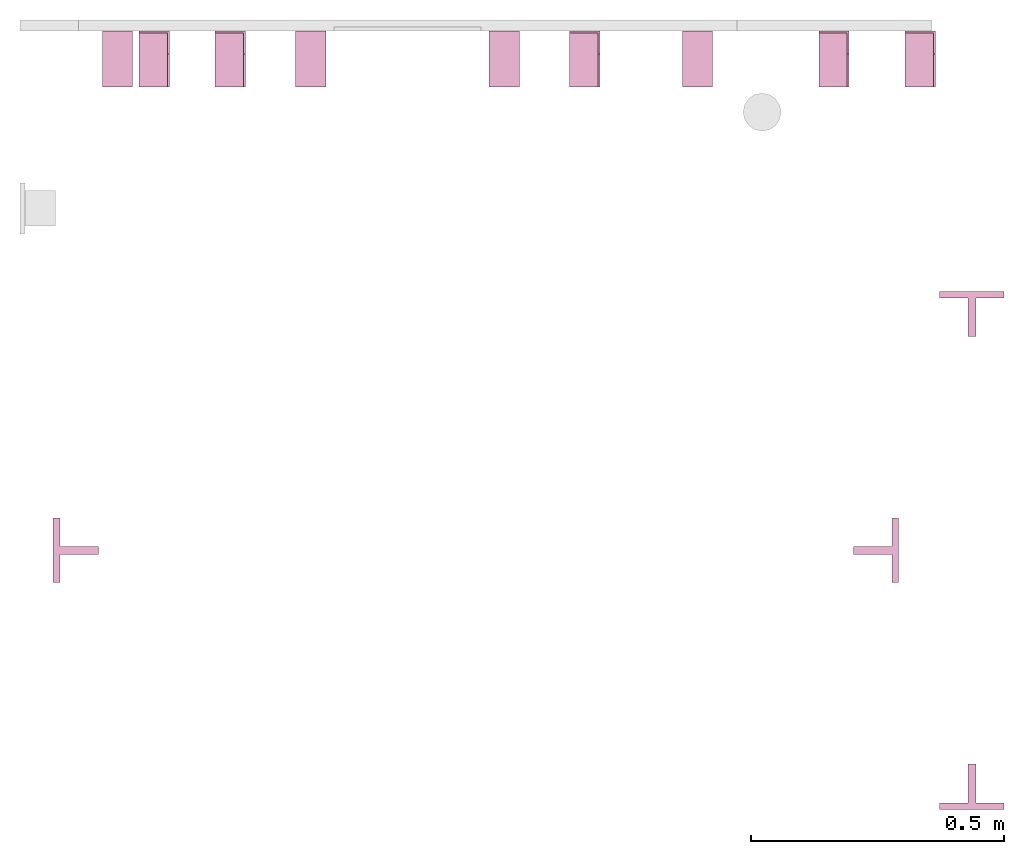
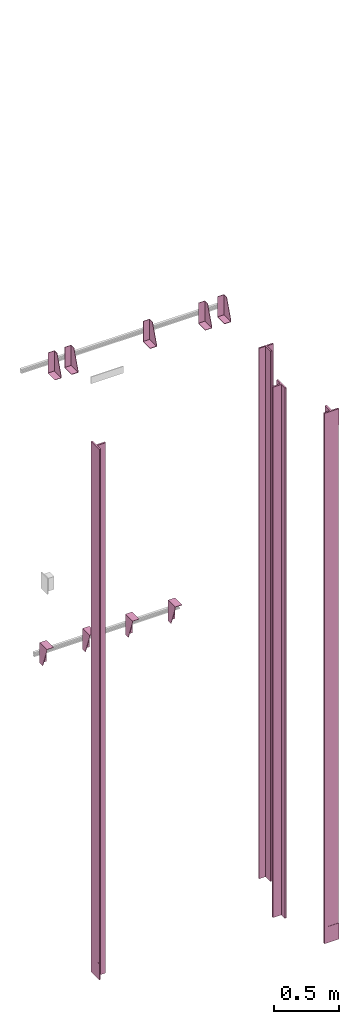
# One storey, part 3 of 3: 13 transport elements.
"""IFC4 building model written with IfcOpenShell, lengths in millimetres."""

from ifc_helpers import new_model, entity, si_unit, converted_unit, frame, origin_with_axes, place, context, subcontext, project, spatial, faceted_brep, element, save


model = new_model("IFC4")

# Units and contexts
context_of_model = context(None, 3, precision=0.01, world=origin_with_axes())
sub_context_1 = subcontext(context_of_model, None, None, "MODEL_VIEW")
sub_context_2 = subcontext(context_of_model, None, None, "MODEL_VIEW")
sub_context_3 = subcontext(context_of_model, None, None, "MODEL_VIEW")
sub_context_4 = subcontext(context_of_model, None, None, "MODEL_VIEW")
sub_context_5 = subcontext(context_of_model, None, None, "MODEL_VIEW")
sub_context_6 = subcontext(context_of_model, None, None, "MODEL_VIEW")
sub_context_7 = subcontext(context_of_model, None, None, "MODEL_VIEW")
sub_context_8 = subcontext(context_of_model, None, None, "MODEL_VIEW")
sub_context_9 = subcontext(context_of_model, None, None, "MODEL_VIEW")
sub_context_10 = subcontext(context_of_model, None, None, "MODEL_VIEW")
sub_context_11 = subcontext(context_of_model, None, None, "MODEL_VIEW")
sub_context_12 = subcontext(context_of_model, None, None, "MODEL_VIEW")
sub_context_13 = subcontext(context_of_model, None, None, "MODEL_VIEW")
ifc_project = project(units=[converted_unit("PLANEANGLEUNIT", "degree", entity("IfcPlaneAngleMeasure", 0.017453292519943), si_unit("PLANEANGLEUNIT", "RADIAN"), dimensions=[0, 0, 0, 0, 0, 0, 0]), si_unit("LENGTHUNIT", "METRE", prefix="MILLI"), si_unit("MASSUNIT", "GRAM", prefix="KILO"), converted_unit("TIMEUNIT", "year", entity("IfcTimeMeasure", 31557600.0), si_unit("TIMEUNIT", "SECOND"), dimensions=[0, 0, 1, 0, 0, 0, 0]), si_unit("THERMODYNAMICTEMPERATUREUNIT", "DEGREE_CELSIUS"), si_unit("AREAUNIT", "SQUARE_METRE"), si_unit("FORCEUNIT", "NEWTON"), si_unit("VOLUMEUNIT", "CUBIC_METRE"), si_unit("PRESSUREUNIT", "PASCAL"), si_unit("SOLIDANGLEUNIT", "STERADIAN")], contexts=[context_of_model])

# Site, building, storey
site = spatial("IfcSite", under=ifc_project)
building = spatial("IfcBuilding", under=site, Name="Document")
placement = place(None, origin_with_axes())
storey_placement = place(placement, frame((0.0, 0.0, -18870.0), z_axis=(0.0, 0.0, 1.0), x_axis=(1.0, 0.0, 0.0)))
storey = spatial("IfcBuildingStorey", under=building, at=storey_placement, Name="P7", Elevation=-18870.0)

# Transport elements
transport_element_1_placement = place(storey_placement, frame((1879.0, 558.5, -17.0), z_axis=(0.0, -1.0, 0.0), x_axis=(0.0, 0.0, -1.0)))
element("IfcTransportElement", 1, at=transport_element_1_placement, inside=storey, ObjectType="Guide Rail", PredefinedType="ELEVATOR", context=sub_context_1, shape_type="Brep", body=[
    faceted_brep([(2347.5, -63.5, 45.0), (2347.5, 63.5, 45.0), (2347.5, 63.5, 44.0), (2347.5, -63.5, 44.0), (2500.0, -63.5, 45.0), (2500.0, -63.5, 44.0), (2500.0, 63.5, 44.0), (2500.0, 63.5, 45.0)], [[[0, 1, 2, 3]], [[4, 5, 6, 7]], [[0, 3, 5, 4]], [[3, 2, 6, 5]], [[2, 1, 7, 6]], [[1, 0, 4, 7]]]),
    faceted_brep([(-2500.0, -63.5, 45.0), (-2500.0, 63.5, 45.0), (-2500.0, 63.5, 44.0), (-2500.0, -63.5, 44.0), (-2347.5, -63.5, 45.0), (-2347.5, -63.5, 44.0), (-2347.5, 63.5, 44.0), (-2347.5, 63.5, 45.0)], [[[0, 1, 2, 3]], [[4, 5, 6, 7]], [[0, 3, 5, 4]], [[3, 2, 6, 5]], [[2, 1, 7, 6]], [[1, 0, 4, 7]]]),
    faceted_brep([(-2500.0, -63.5, 44.5), (-2500.0, -63.5, 31.79998779296875), (2500.0, -63.5, 31.79998779296875), (2500.0, -63.5, 44.5), (-2500.0, -7.93994140625, 31.79998779296875), (-2500.0, -7.93994140625, -44.5), (2500.0, -7.93994140625, -44.5), (2500.0, -7.93994140625, 31.79998779296875), (2500.0, 7.93994140625, -44.5), (-2500.0, 7.93994140625, -44.5), (-2500.0, 7.93994140625, 31.79998779296875), (2500.0, 7.93994140625, 31.79998779296875), (2500.0, 63.5, 31.79998779296875), (-2500.0, 63.5, 31.79998779296875), (-2500.0, 63.5, 44.5), (2500.0, 63.5, 44.5)], [[[0, 1, 2, 3]], [[4, 5, 6, 7]], [[8, 9, 10, 11]], [[12, 13, 14, 15]], [[15, 14, 0, 3]], [[1, 4, 7, 2]], [[10, 13, 12, 11]], [[5, 9, 8, 6]], [[2, 7, 6, 8, 11, 12, 15, 3]], [[14, 13, 10, 9, 5, 4, 1, 0]]]),
])
transport_element_2_placement = place(storey_placement, frame((1879.0, 1491.5, -17.0), z_axis=(0.0, 1.0, 0.0), x_axis=(0.0, 0.0, 1.0)))
element("IfcTransportElement", 2, at=transport_element_2_placement, inside=storey, ObjectType="Guide Rail", PredefinedType="ELEVATOR", context=sub_context_2, shape_type="Brep", body=[
    faceted_brep([(2347.5, -63.5, 45.0), (2347.5, 63.5, 45.0), (2347.5, 63.5, 44.0), (2347.5, -63.5, 44.0), (2500.0, -63.5, 45.0), (2500.0, -63.5, 44.0), (2500.0, 63.5, 44.0), (2500.0, 63.5, 45.0)], [[[0, 1, 2, 3]], [[4, 5, 6, 7]], [[0, 3, 5, 4]], [[3, 2, 6, 5]], [[2, 1, 7, 6]], [[1, 0, 4, 7]]]),
    faceted_brep([(-2500.0, -63.5, 45.0), (-2500.0, 63.5, 45.0), (-2500.0, 63.5, 44.0), (-2500.0, -63.5, 44.0), (-2347.5, -63.5, 45.0), (-2347.5, -63.5, 44.0), (-2347.5, 63.5, 44.0), (-2347.5, 63.5, 45.0)], [[[0, 1, 2, 3]], [[4, 5, 6, 7]], [[0, 3, 5, 4]], [[3, 2, 6, 5]], [[2, 1, 7, 6]], [[1, 0, 4, 7]]]),
    faceted_brep([(2500.0, -63.5, 31.800048828125), (2500.0, -63.5, 44.5), (-2500.0, -63.5, 44.5), (-2500.0, -63.5, 31.800048828125), (2500.0, -7.93994140625, -44.5), (2500.0, -7.93994140625, 31.800048828125), (-2500.0, -7.93994140625, 31.800048828125), (-2500.0, -7.93994140625, -44.5), (-2500.0, 7.93994140625, 31.800048828125), (2500.0, 7.93994140625, 31.800048828125), (2500.0, 7.93994140625, -44.5), (-2500.0, 7.93994140625, -44.5), (-2500.0, 63.5, 44.5), (2500.0, 63.5, 44.5), (2500.0, 63.5, 31.800048828125), (-2500.0, 63.5, 31.800048828125)], [[[0, 1, 2, 3]], [[4, 5, 6, 7]], [[8, 9, 10, 11]], [[12, 13, 14, 15]], [[6, 5, 0, 3]], [[1, 13, 12, 2]], [[11, 10, 4, 7]], [[9, 8, 15, 14]], [[2, 12, 15, 8, 11, 7, 6, 3]], [[5, 4, 10, 9, 14, 13, 1, 0]]]),
])
transport_element_3_placement = place(storey_placement, frame((110.5, 1025.0, -17.0), z_axis=(-1.0, 0.0, 0.0), x_axis=(0.0, 0.0, -1.0)))
element("IfcTransportElement", 3, at=transport_element_3_placement, inside=storey, ObjectType="Guide Rail", PredefinedType="ELEVATOR", context=sub_context_3, shape_type="Brep", body=[
    faceted_brep([(2347.5, -63.5, 45.0), (2347.5, 63.5, 45.0), (2347.5, 63.5, 44.0), (2347.5, -63.5, 44.0), (2500.0, -63.5, 45.0), (2500.0, -63.5, 44.0), (2500.0, 63.5, 44.0), (2500.0, 63.5, 45.0)], [[[0, 1, 2, 3]], [[4, 5, 6, 7]], [[0, 3, 5, 4]], [[3, 2, 6, 5]], [[2, 1, 7, 6]], [[1, 0, 4, 7]]]),
    faceted_brep([(-2500.0, -63.5, 45.0), (-2500.0, 63.5, 45.0), (-2500.0, 63.5, 44.0), (-2500.0, -63.5, 44.0), (-2347.5, -63.5, 45.0), (-2347.5, -63.5, 44.0), (-2347.5, 63.5, 44.0), (-2347.5, 63.5, 45.0)], [[[0, 1, 2, 3]], [[4, 5, 6, 7]], [[0, 3, 5, 4]], [[3, 2, 6, 5]], [[2, 1, 7, 6]], [[1, 0, 4, 7]]]),
    faceted_brep([(-2500.0, 63.5, 44.5), (-2500.0, -63.5, 44.5), (2500.0, -63.5, 44.5), (2500.0, 63.5, 44.5), (2500.0, 7.94000244140625, 31.800003051757812), (-2500.0, 7.94000244140625, 31.800003051757812), (-2500.0, 63.5, 31.79998779296875), (2500.0, 63.5, 31.79998779296875), (2500.0, -63.5, 31.79998779296875), (-2500.0, -63.5, 31.79998779296875), (-2500.0, -7.93994140625, 31.79998779296875), (2500.0, -7.93994140625, 31.79998779296875), (2500.0, -7.93994140625, -44.5), (-2500.0, -7.93994140625, -44.5), (-2500.0, 7.94000244140625, -44.5), (2500.0, 7.94000244140625, -44.5)], [[[0, 1, 2, 3]], [[4, 5, 6, 7]], [[8, 9, 10, 11]], [[12, 13, 14, 15]], [[7, 6, 0, 3]], [[15, 14, 5, 4]], [[10, 13, 12, 11]], [[1, 9, 8, 2]], [[2, 8, 11, 12, 15, 4, 7, 3]], [[6, 5, 14, 13, 10, 9, 1, 0]]]),
])
transport_element_4_placement = place(storey_placement, frame((1689.5, 1025.0, -17.0), z_axis=(1.0, 0.0, 0.0), x_axis=(0.0, 0.0, 1.0)))
element("IfcTransportElement", 4, at=transport_element_4_placement, inside=storey, ObjectType="Guide Rail", PredefinedType="ELEVATOR", context=sub_context_4, shape_type="Brep", body=[
    faceted_brep([(-2500.0, -63.5, 45.0), (-2500.0, 63.5, 45.0), (-2500.0, 63.5, 44.0), (-2500.0, -63.5, 44.0), (-2347.5, -63.5, 45.0), (-2347.5, -63.5, 44.0), (-2347.5, 63.5, 44.0), (-2347.5, 63.5, 45.0)], [[[0, 1, 2, 3]], [[4, 5, 6, 7]], [[0, 3, 5, 4]], [[3, 2, 6, 5]], [[2, 1, 7, 6]], [[1, 0, 4, 7]]]),
    faceted_brep([(2347.5, -63.5, 45.0), (2347.5, 63.5, 45.0), (2347.5, 63.5, 44.0), (2347.5, -63.5, 44.0), (2500.0, -63.5, 45.0), (2500.0, -63.5, 44.0), (2500.0, 63.5, 44.0), (2500.0, 63.5, 45.0)], [[[0, 1, 2, 3]], [[4, 5, 6, 7]], [[0, 3, 5, 4]], [[3, 2, 6, 5]], [[2, 1, 7, 6]], [[1, 0, 4, 7]]]),
    faceted_brep([(2500.0, 7.94000244140625, -44.5), (2500.0, -7.93994140625, -44.5), (-2500.0, -7.93994140625, -44.5), (-2500.0, 7.94000244140625, -44.5), (2500.0, 63.5, 31.800048828125), (2500.0, 7.94000244140625, 31.800048828125), (-2500.0, 7.94000244140625, 31.800048828125), (-2500.0, 63.5, 31.800048828125), (-2500.0, -63.5, 44.5), (2500.0, -63.5, 44.5), (2500.0, 63.5, 44.5), (-2500.0, 63.5, 44.5), (2500.0, -7.93994140625, 31.800048828125), (2500.0, -63.5, 31.800048828125), (-2500.0, -63.5, 31.800048828125), (-2500.0, -7.93994140625, 31.800048828125)], [[[0, 1, 2, 3]], [[4, 5, 6, 7]], [[8, 9, 10, 11]], [[12, 13, 14, 15]], [[6, 5, 0, 3]], [[1, 12, 15, 2]], [[11, 10, 4, 7]], [[13, 9, 8, 14]], [[2, 15, 14, 8, 11, 7, 6, 3]], [[5, 4, 10, 9, 13, 12, 1, 0]]]),
])
transport_element_5_placement = place(storey_placement, frame((1777.0, 2050.0, 2580.0), z_axis=(0.0, 0.0, 1.0), x_axis=(-1.0, 0.0, 0.0)))
element("IfcTransportElement", 5, at=transport_element_5_placement, inside=storey, PredefinedType="ELEVATOR", context=sub_context_5, shape_type="Brep", body=[
    faceted_brep([(30.0, 110.0, -93.0), (30.0, 4.0, -93.0), (30.0, 4.0, 97.0), (30.0, 0.0, 97.0), (30.0, 0.0, -97.0), (30.0, 110.0, -97.0), (-30.0, 0.0, -97.0), (-30.0, 0.0, 97.0), (-30.0, 4.0, 97.0), (-30.0, 4.0, -93.0), (-30.0, 110.0, -93.0), (-30.0, 110.0, -97.0)], [[[0, 1, 2, 3, 4, 5]], [[6, 7, 8, 9, 10, 11]], [[11, 10, 0, 5]], [[9, 8, 2, 1]], [[3, 7, 6, 4]], [[4, 6, 11, 5]], [[10, 9, 1, 0]], [[8, 7, 3, 2]]]),
    faceted_brep([(-30.0, 4.0, -93.0), (-30.0, 4.0, 97.0), (-30.0, 45.0, 97.0), (-30.0, 110.0, -82.0), (-30.0, 110.0, -93.0), (-26.0, 4.0, -93.0), (-26.0, 110.0, -93.0), (-26.0, 110.0, -82.0), (-26.0, 45.0, 97.0), (-26.0, 4.0, 97.0)], [[[0, 1, 2, 3, 4]], [[5, 6, 7, 8, 9]], [[5, 0, 4, 6]], [[6, 4, 3, 7]], [[7, 3, 2, 8]], [[8, 2, 1, 9]], [[9, 1, 0, 5]]]),
])
transport_element_6_placement = place(storey_placement, frame((1607.0, 2050.0, 2580.0), z_axis=(0.0, 0.0, 1.0), x_axis=(-1.0, 0.0, 0.0)))
element("IfcTransportElement", 6, at=transport_element_6_placement, inside=storey, PredefinedType="ELEVATOR", context=sub_context_6, shape_type="Brep", body=[
    faceted_brep([(-30.0, 4.0, -93.0), (-30.0, 4.0, 97.0), (-30.0, 45.0, 97.0), (-30.0, 110.0, -82.0), (-30.0, 110.0, -93.0), (-26.0, 4.0, -93.0), (-26.0, 110.0, -93.0), (-26.0, 110.0, -82.0), (-26.0, 45.0, 97.0), (-26.0, 4.0, 97.0)], [[[0, 1, 2, 3, 4]], [[5, 6, 7, 8, 9]], [[5, 0, 4, 6]], [[6, 4, 3, 7]], [[7, 3, 2, 8]], [[8, 2, 1, 9]], [[9, 1, 0, 5]]]),
    faceted_brep([(30.0, 110.0, -93.0), (30.0, 4.0, -93.0), (30.0, 4.0, 97.0), (30.0, 0.0, 97.0), (30.0, 0.0, -97.0), (30.0, 110.0, -97.0), (-30.0, 0.0, -97.0), (-30.0, 0.0, 97.0), (-30.0, 4.0, 97.0), (-30.0, 4.0, -93.0), (-30.0, 110.0, -93.0), (-30.0, 110.0, -97.0)], [[[0, 1, 2, 3, 4, 5]], [[6, 7, 8, 9, 10, 11]], [[11, 10, 0, 5]], [[9, 8, 2, 1]], [[3, 7, 6, 4]], [[4, 6, 11, 5]], [[10, 9, 1, 0]], [[8, 7, 3, 2]]]),
])
transport_element_7_placement = place(storey_placement, frame((1115.0, 2050.0, 2580.0), z_axis=(0.0, 0.0, 1.0), x_axis=(-1.0, 0.0, 0.0)))
element("IfcTransportElement", 7, at=transport_element_7_placement, inside=storey, PredefinedType="ELEVATOR", context=sub_context_7, shape_type="Brep", body=[
    faceted_brep([(30.0, 110.0, -93.0), (30.0, 4.0, -93.0), (30.0, 4.0, 97.0), (30.0, 0.0, 97.0), (30.0, 0.0, -97.0), (30.0, 110.0, -97.0), (-30.0, 0.0, -97.0), (-30.0, 0.0, 97.0), (-30.0, 4.0, 97.0), (-30.0, 4.0, -93.0), (-30.0, 110.0, -93.0), (-30.0, 110.0, -97.0)], [[[0, 1, 2, 3, 4, 5]], [[6, 7, 8, 9, 10, 11]], [[11, 10, 0, 5]], [[9, 8, 2, 1]], [[3, 7, 6, 4]], [[4, 6, 11, 5]], [[10, 9, 1, 0]], [[8, 7, 3, 2]]]),
    faceted_brep([(-30.0, 4.0, -93.0), (-30.0, 4.0, 97.0), (-30.0, 45.0, 97.0), (-30.0, 110.0, -82.0), (-30.0, 110.0, -93.0), (-26.0, 4.0, -93.0), (-26.0, 110.0, -93.0), (-26.0, 110.0, -82.0), (-26.0, 45.0, 97.0), (-26.0, 4.0, 97.0)], [[[0, 1, 2, 3, 4]], [[5, 6, 7, 8, 9]], [[5, 0, 4, 6]], [[6, 4, 3, 7]], [[7, 3, 2, 8]], [[8, 2, 1, 9]], [[9, 1, 0, 5]]]),
])
transport_element_8_placement = place(storey_placement, frame((415.0, 2050.0, 2580.0), z_axis=(0.0, 0.0, 1.0), x_axis=(-1.0, 0.0, 0.0)))
element("IfcTransportElement", 8, at=transport_element_8_placement, inside=storey, PredefinedType="ELEVATOR", context=sub_context_8, shape_type="Brep", body=[
    faceted_brep([(-30.0, 4.0, -93.0), (-30.0, 4.0, 97.0), (-30.0, 45.0, 97.0), (-30.0, 110.0, -82.0), (-30.0, 110.0, -93.0), (-26.0, 4.0, -93.0), (-26.0, 110.0, -93.0), (-26.0, 110.0, -82.0), (-26.0, 45.0, 97.0), (-26.0, 4.0, 97.0)], [[[0, 1, 2, 3, 4]], [[5, 6, 7, 8, 9]], [[5, 0, 4, 6]], [[6, 4, 3, 7]], [[7, 3, 2, 8]], [[8, 2, 1, 9]], [[9, 1, 0, 5]]]),
    faceted_brep([(30.0, 110.0, -93.0), (30.0, 4.0, -93.0), (30.0, 4.0, 97.0), (30.0, 0.0, 97.0), (30.0, 0.0, -97.0), (30.0, 110.0, -97.0), (-30.0, 0.0, -97.0), (-30.0, 0.0, 97.0), (-30.0, 4.0, 97.0), (-30.0, 4.0, -93.0), (-30.0, 110.0, -93.0), (-30.0, 110.0, -97.0)], [[[0, 1, 2, 3, 4, 5]], [[6, 7, 8, 9, 10, 11]], [[11, 10, 0, 5]], [[9, 8, 2, 1]], [[3, 7, 6, 4]], [[4, 6, 11, 5]], [[10, 9, 1, 0]], [[8, 7, 3, 2]]]),
])
transport_element_9_placement = place(storey_placement, frame((265.0, 2050.0, 2580.0), z_axis=(0.0, 0.0, 1.0), x_axis=(-1.0, 0.0, 0.0)))
element("IfcTransportElement", 9, at=transport_element_9_placement, inside=storey, PredefinedType="ELEVATOR", context=sub_context_9, shape_type="Brep", body=[
    faceted_brep([(30.0, 110.0, -93.0), (30.0, 4.0, -93.0), (30.0, 4.0, 97.0), (30.0, 0.0, 97.0), (30.0, 0.0, -97.0), (30.0, 110.0, -97.0), (-30.0, 0.0, -97.0), (-30.0, 0.0, 97.0), (-30.0, 4.0, 97.0), (-30.0, 4.0, -93.0), (-30.0, 110.0, -93.0), (-30.0, 110.0, -97.0)], [[[0, 1, 2, 3, 4, 5]], [[6, 7, 8, 9, 10, 11]], [[11, 10, 0, 5]], [[9, 8, 2, 1]], [[3, 7, 6, 4]], [[4, 6, 11, 5]], [[10, 9, 1, 0]], [[8, 7, 3, 2]]]),
    faceted_brep([(-30.0, 4.0, -93.0), (-30.0, 4.0, 97.0), (-30.0, 45.0, 97.0), (-30.0, 110.0, -82.0), (-30.0, 110.0, -93.0), (-26.0, 4.0, -93.0), (-26.0, 110.0, -93.0), (-26.0, 110.0, -82.0), (-26.0, 45.0, 97.0), (-26.0, 4.0, 97.0)], [[[0, 1, 2, 3, 4]], [[5, 6, 7, 8, 9]], [[5, 0, 4, 6]], [[6, 4, 3, 7]], [[7, 3, 2, 8]], [[8, 2, 1, 9]], [[9, 1, 0, 5]]]),
])
transport_element_10_placement = place(storey_placement, frame((192.5, 2050.0, -30.0), z_axis=(0.0, 0.0, -1.0), x_axis=(1.0, 0.0, 0.0)))
element("IfcTransportElement", 10, at=transport_element_10_placement, inside=storey, PredefinedType="ELEVATOR", context=sub_context_10, shape_type="Brep", body=[
    faceted_brep([(-30.0, 4.0, 4.0), (-30.0, 110.0, 4.0), (-30.0, 110.0, 0.0), (-30.0, 0.0, 0.0), (-30.0, 0.0, 194.0), (-30.0, 4.0, 194.0), (30.0, 0.0, 194.0), (30.0, 0.0, 0.0), (30.0, 110.0, 0.0), (30.0, 110.0, 4.0), (30.0, 4.0, 4.0), (30.0, 4.0, 194.0)], [[[0, 1, 2, 3, 4, 5]], [[6, 7, 8, 9, 10, 11]], [[11, 10, 0, 5]], [[3, 7, 6, 4]], [[9, 8, 2, 1]], [[4, 6, 11, 5]], [[0, 10, 9, 1]], [[8, 7, 3, 2]]]),
    faceted_brep([(-30.0, 4.0, 4.0), (-30.0, 4.0, 194.0), (-30.0, 45.0, 194.0), (-30.0, 110.0, 15.0), (-30.0, 110.0, 4.0), (-26.0, 4.0, 4.0), (-26.0, 110.0, 4.0), (-26.0, 110.0, 15.0), (-26.0, 45.0, 194.0), (-26.0, 4.0, 194.0)], [[[0, 1, 2, 3, 4]], [[5, 6, 7, 8, 9]], [[5, 0, 4, 6]], [[6, 4, 3, 7]], [[7, 3, 2, 8]], [[8, 2, 1, 9]], [[9, 1, 0, 5]]]),
])
transport_element_11_placement = place(storey_placement, frame((573.84, 2050.0, -30.0), z_axis=(0.0, 0.0, -1.0), x_axis=(1.0, 0.0, 0.0)))
element("IfcTransportElement", 11, at=transport_element_11_placement, inside=storey, PredefinedType="ELEVATOR", context=sub_context_11, shape_type="Brep", body=[
    faceted_brep([(-29.999973144531282, 4.0, 4.0), (-29.999973144531282, 4.0, 194.0), (-29.999973144531282, 45.0, 194.0), (-29.999973144531282, 110.0, 15.0), (-29.999973144531282, 110.0, 4.0), (-25.999973144531282, 4.0, 4.0), (-25.999973144531282, 110.0, 4.0), (-25.999973144531282, 110.0, 15.0), (-25.999973144531282, 45.0, 194.0), (-25.999973144531282, 4.0, 194.0)], [[[0, 1, 2, 3, 4]], [[5, 6, 7, 8, 9]], [[5, 0, 4, 6]], [[6, 4, 3, 7]], [[7, 3, 2, 8]], [[8, 2, 1, 9]], [[9, 1, 0, 5]]]),
    faceted_brep([(-29.999973144531282, 4.0, 4.0), (-29.999973144531282, 110.0, 4.0), (-29.999973144531282, 110.0, 0.0), (-29.999973144531282, 0.0, 0.0), (-29.999973144531282, 0.0, 194.0), (-29.999973144531282, 4.0, 194.0), (30.000026855468718, 0.0, 194.0), (30.000026855468718, 0.0, 0.0), (30.000026855468718, 110.0, 0.0), (30.000026855468718, 110.0, 4.0), (30.000026855468718, 4.0, 4.0), (30.000026855468718, 4.0, 194.0)], [[[0, 1, 2, 3, 4, 5]], [[6, 7, 8, 9, 10, 11]], [[11, 10, 0, 5]], [[3, 7, 6, 4]], [[9, 8, 2, 1]], [[4, 6, 11, 5]], [[0, 10, 9, 1]], [[8, 7, 3, 2]]]),
])
transport_element_12_placement = place(storey_placement, frame((956.16, 2050.0, -30.0), z_axis=(0.0, 0.0, -1.0), x_axis=(1.0, 0.0, 0.0)))
element("IfcTransportElement", 12, at=transport_element_12_placement, inside=storey, PredefinedType="ELEVATOR", context=sub_context_12, shape_type="Brep", body=[
    faceted_brep([(-30.000026855468718, 4.0, 4.0), (-30.000026855468718, 110.0, 4.0), (-30.000026855468718, 110.0, 0.0), (-30.000026855468718, 0.0, 0.0), (-30.000026855468718, 0.0, 194.0), (-30.000026855468718, 4.0, 194.0), (29.999973144531282, 0.0, 194.0), (29.999973144531282, 0.0, 0.0), (29.999973144531282, 110.0, 0.0), (29.999973144531282, 110.0, 4.0), (29.999973144531282, 4.0, 4.0), (29.999973144531282, 4.0, 194.0)], [[[0, 1, 2, 3, 4, 5]], [[6, 7, 8, 9, 10, 11]], [[11, 10, 0, 5]], [[3, 7, 6, 4]], [[9, 8, 2, 1]], [[4, 6, 11, 5]], [[0, 10, 9, 1]], [[8, 7, 3, 2]]]),
    faceted_brep([(-30.000026855468718, 4.0, 4.0), (-30.000026855468718, 4.0, 194.0), (-30.000026855468718, 45.0, 194.0), (-30.000026855468718, 110.0, 15.0), (-30.000026855468718, 110.0, 4.0), (-26.000026855468718, 4.0, 4.0), (-26.000026855468718, 110.0, 4.0), (-26.000026855468718, 110.0, 15.0), (-26.000026855468718, 45.0, 194.0), (-26.000026855468718, 4.0, 194.0)], [[[0, 1, 2, 3, 4]], [[5, 6, 7, 8, 9]], [[5, 0, 4, 6]], [[6, 4, 3, 7]], [[7, 3, 2, 8]], [[8, 2, 1, 9]], [[9, 1, 0, 5]]]),
])
transport_element_13_placement = place(storey_placement, frame((1337.5, 2050.0, -30.0), z_axis=(0.0, 0.0, -1.0), x_axis=(1.0, 0.0, 0.0)))
element("IfcTransportElement", 13, at=transport_element_13_placement, inside=storey, PredefinedType="ELEVATOR", context=sub_context_13, shape_type="Brep", body=[
    faceted_brep([(-30.0, 4.0, 4.0), (-30.0, 110.0, 4.0), (-30.0, 110.0, 0.0), (-30.0, 0.0, 0.0), (-30.0, 0.0, 194.0), (-30.0, 4.0, 194.0), (30.0, 0.0, 194.0), (30.0, 0.0, 0.0), (30.0, 110.0, 0.0), (30.0, 110.0, 4.0), (30.0, 4.0, 4.0), (30.0, 4.0, 194.0)], [[[0, 1, 2, 3, 4, 5]], [[6, 7, 8, 9, 10, 11]], [[11, 10, 0, 5]], [[3, 7, 6, 4]], [[9, 8, 2, 1]], [[4, 6, 11, 5]], [[0, 10, 9, 1]], [[8, 7, 3, 2]]]),
    faceted_brep([(-30.0, 4.0, 4.0), (-30.0, 4.0, 194.0), (-30.0, 45.0, 194.0), (-30.0, 110.0, 15.0), (-30.0, 110.0, 4.0), (-26.0, 4.0, 4.0), (-26.0, 110.0, 4.0), (-26.0, 110.0, 15.0), (-26.0, 45.0, 194.0), (-26.0, 4.0, 194.0)], [[[0, 1, 2, 3, 4]], [[5, 6, 7, 8, 9]], [[5, 0, 4, 6]], [[6, 4, 3, 7]], [[7, 3, 2, 8]], [[8, 2, 1, 9]], [[9, 1, 0, 5]]]),
])

save(model, "model.ifc")
